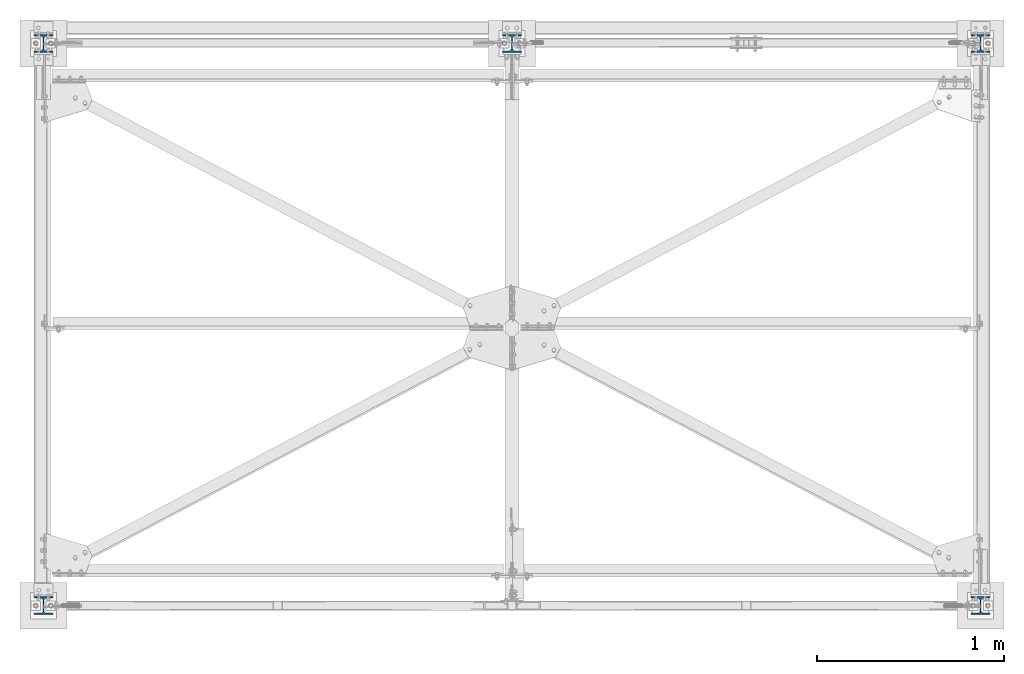
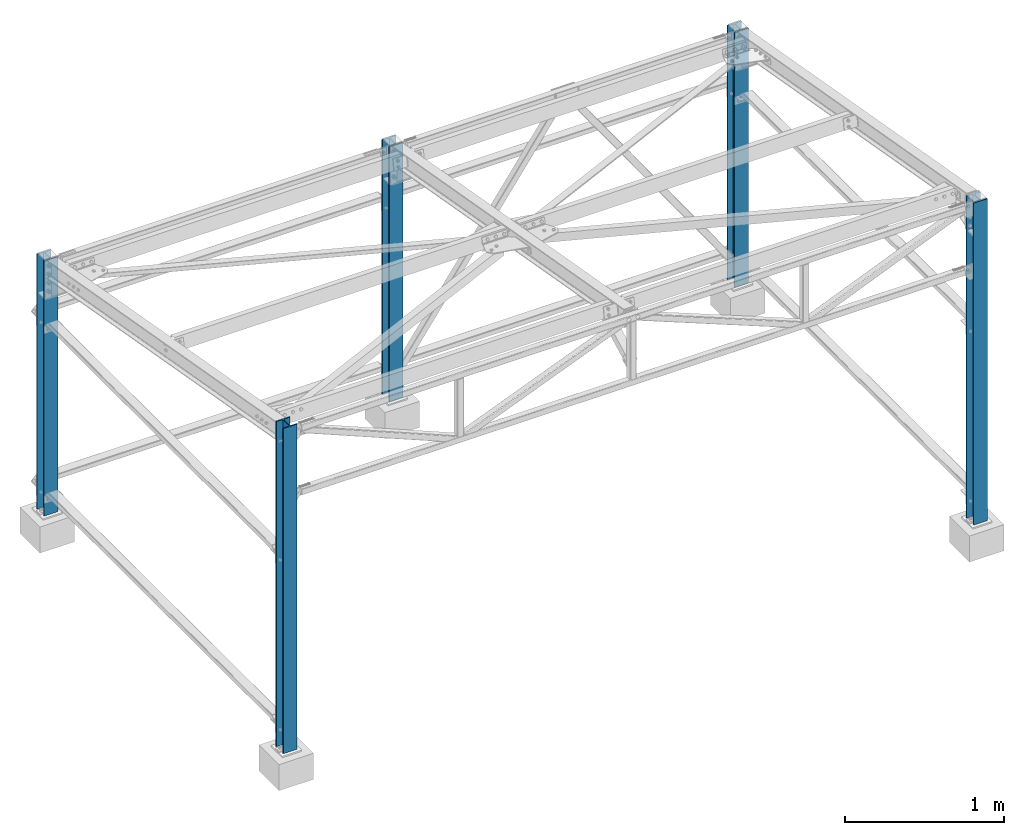
# One storey, part 1 of 28: 5 columns, 5 elements without a shape of their own.
"""IFC2X3 building model written with IfcOpenShell, lengths in millimetres."""

from ifc_helpers import new_model, si_unit, frame, origin_with_axes, origin_2d_with_axis, place, context, subcontext, project, spatial, i_section, extrude, clip, halfspace, material, type_object, element, aggregate, save


model = new_model("IFC2X3")

# Units and contexts
model_context = context("Model", 3, precision=1e-05, world=origin_with_axes())
body_context = subcontext(model_context, "Body", "Model", "MODEL_VIEW")
ifc_project = project(units=[si_unit("LENGTHUNIT", "METRE", prefix="MILLI"), si_unit("AREAUNIT", "SQUARE_METRE"), si_unit("VOLUMEUNIT", "CUBIC_METRE"), si_unit("MASSUNIT", "GRAM", prefix="KILO"), si_unit("TIMEUNIT", "SECOND"), si_unit("PLANEANGLEUNIT", "RADIAN"), si_unit("SOLIDANGLEUNIT", "STERADIAN"), si_unit("THERMODYNAMICTEMPERATUREUNIT", "DEGREE_CELSIUS"), si_unit("LUMINOUSINTENSITYUNIT", "LUMEN")], contexts=[model_context])

# Site, building, storey
site_placement = place(None, origin_with_axes())
site = spatial("IfcSite", under=ifc_project, at=site_placement, CompositionType="ELEMENT")
building_placement = place(site_placement, origin_with_axes())
building = spatial("IfcBuilding", under=site, at=building_placement, Name="Undefined", CompositionType="ELEMENT")
storey_placement = place(building_placement, origin_with_axes())
storey = spatial("IfcBuildingStorey", under=building, at=storey_placement, Name="Undefined", CompositionType="ELEMENT", Elevation=0.0)

# Assembly, column
assembly_1_placement = place(storey_placement, origin_with_axes())
assembly_1 = element("IfcElementAssembly", 1, at=assembly_1_placement, inside=storey, Name="POTEAU AV", AssemblyPlace="NOTDEFINED", PredefinedType="NOTDEFINED")
ifc_material = material(Name="STEEL/S235JR")
column_type = type_object("IfcColumnType", Name="HEA100", PredefinedType="NOTDEFINED")
column_1_placement = place(assembly_1_placement, frame((5000.00000000035, 3000.00000000094, 199.999895901637), z_axis=(0.0, 0.0, 1.0), x_axis=(0.0, 1.0, 0.0)))
column_1 = element("IfcColumn", 2, at=column_1_placement, type_object=column_type, material=ifc_material, Name="POTEAU AV", context=body_context, shape_type="Clipping", body=[
    clip(clip(extrude(i_section(OverallWidth=100.0, OverallDepth=96.0, WebThickness=5.0, FlangeThickness=8.0, FilletRadius=12.0, at=origin_2d_with_axis()), frame((0.0, 0.0, 2000.00000000045), z_axis=(0.0, 0.0, -1.0), x_axis=(0.0, 1.0, 0.0)), (0.0, 0.0, 1.0), 2000.0), halfspace(frame((48.0, 0.0, 1961.73878080369), z_axis=(0.0, 0.0, -1.0), x_axis=(0.0, 1.0, 0.0)), True)), halfspace(frame((-48.0, 0.0, 9.99999999945612), z_axis=(0.0, 0.0, 1.0), x_axis=(0.0, 1.0, 0.0)), True)),
])
aggregate(assembly_1, [column_1])

assembly_2_placement = place(storey_placement, origin_with_axes())
assembly_2 = element("IfcElementAssembly", 3, at=assembly_2_placement, inside=storey, Name="POTEAU AV", AssemblyPlace="NOTDEFINED", PredefinedType="NOTDEFINED")
column_2_placement = place(assembly_2_placement, frame((5000.00000000035, 9.38356947699504e-10, 199.999895901637), z_axis=(0.0, 0.0, 1.0), x_axis=(0.0, 1.0, 0.0)))
column_2 = element("IfcColumn", 4, at=column_2_placement, type_object=column_type, material=ifc_material, Name="POTEAU AV", context=body_context, shape_type="Clipping", body=[
    clip(clip(extrude(i_section(OverallWidth=100.0, OverallDepth=96.0, WebThickness=5.0, FlangeThickness=8.0, FilletRadius=12.0, at=origin_2d_with_axis()), frame((0.0, 0.0, 2500.00000000056), z_axis=(0.0, 0.0, -1.0), x_axis=(0.0, 1.0, 0.0)), (0.0, 0.0, 1.0), 2500.0), halfspace(frame((-48.0000000000081, 9.09494701772928e-13, 2474.92013007251), z_axis=(0.0, 0.0, -1.0), x_axis=(0.0, -1.0, 0.0)), True)), halfspace(frame((-48.0, 0.0, 9.99999999945612), z_axis=(0.0, 0.0, 1.0), x_axis=(0.0, 1.0, 0.0)), True)),
])
aggregate(assembly_2, [column_2])

assembly_3_placement = place(storey_placement, origin_with_axes())
assembly_3 = element("IfcElementAssembly", 5, at=assembly_3_placement, inside=storey, Name="POTEAU AV", AssemblyPlace="NOTDEFINED", PredefinedType="NOTDEFINED")
column_3_placement = place(assembly_3_placement, frame((2499.99999999999, 3000.00000000096, 199.999895901637), z_axis=(0.0, 0.0, 1.0), x_axis=(0.0, 1.0, 0.0)))
column_3 = element("IfcColumn", 6, at=column_3_placement, type_object=column_type, material=ifc_material, Name="POTEAU AV", context=body_context, shape_type="Clipping", body=[
    clip(clip(extrude(i_section(OverallWidth=100.0, OverallDepth=96.0, WebThickness=5.0, FlangeThickness=8.0, FilletRadius=12.0, at=origin_2d_with_axis()), frame((0.0, 0.0, 2000.00000000045), z_axis=(0.0, 0.0, -1.0), x_axis=(0.0, 1.0, 0.0)), (0.0, 0.0, 1.0), 2000.0), halfspace(frame((48.0, 0.0, 1961.73878080369), z_axis=(0.0, 0.0, -1.0), x_axis=(0.0, 1.0, 0.0)), True)), halfspace(frame((-48.0, 0.0, 9.99999999945612), z_axis=(0.0, 0.0, 1.0), x_axis=(0.0, 1.0, 0.0)), True)),
])
aggregate(assembly_3, [column_3])

assembly_4_placement = place(storey_placement, origin_with_axes())
assembly_4 = element("IfcElementAssembly", 7, at=assembly_4_placement, inside=storey, Name="Poteau AR", AssemblyPlace="NOTDEFINED", PredefinedType="NOTDEFINED")
column_4_placement = place(assembly_4_placement, frame((-3.81533027393743e-10, 3000.00000000099, 199.999895901637), z_axis=(0.0, 0.0, 1.0), x_axis=(0.0, 1.0, 0.0)))
column_4 = element("IfcColumn", 8, at=column_4_placement, type_object=column_type, material=ifc_material, Name="Poteau AR", context=body_context, shape_type="Clipping", body=[
    clip(clip(extrude(i_section(OverallWidth=100.0, OverallDepth=96.0, WebThickness=5.0, FlangeThickness=8.0, FilletRadius=12.0, at=origin_2d_with_axis()), frame((0.0, 0.0, 2000.00000000045), z_axis=(0.0, 0.0, -1.0), x_axis=(0.0, 1.0, 0.0)), (0.0, 0.0, 1.0), 2000.0), halfspace(frame((48.0, 0.0, 1961.73878080369), z_axis=(0.0, 0.0, -1.0), x_axis=(0.0, 1.0, 0.0)), True)), halfspace(frame((-48.0, 0.0, 9.99999999945612), z_axis=(0.0, 0.0, 1.0), x_axis=(0.0, 1.0, 0.0)), True)),
])
aggregate(assembly_4, [column_4])

assembly_5_placement = place(storey_placement, origin_with_axes())
assembly_5 = element("IfcElementAssembly", 9, at=assembly_5_placement, inside=storey, Name="POTEAU AV", AssemblyPlace="NOTDEFINED", PredefinedType="NOTDEFINED")
column_5_placement = place(assembly_5_placement, frame((-3.81533027393743e-10, 9.91487780765965e-10, 199.999895901637), z_axis=(0.0, 0.0, 1.0), x_axis=(0.0, 1.0, 0.0)))
column_5 = element("IfcColumn", 10, at=column_5_placement, type_object=column_type, material=ifc_material, Name="POTEAU AV", context=body_context, shape_type="Clipping", body=[
    clip(extrude(i_section(OverallWidth=100.0, OverallDepth=96.0, WebThickness=5.0, FlangeThickness=8.0, FilletRadius=12.0, at=origin_2d_with_axis()), frame((0.0, 0.0, 2500.00000000056), z_axis=(0.0, 0.0, -1.0), x_axis=(0.0, 1.0, 0.0)), (0.0, 0.0, 1.0), 2500.0), halfspace(frame((-48.0, 0.0, 9.99999999945612), z_axis=(0.0, 0.0, 1.0), x_axis=(0.0, 1.0, 0.0)), True)),
])
aggregate(assembly_5, [column_5])

save(model, "model.ifc")
